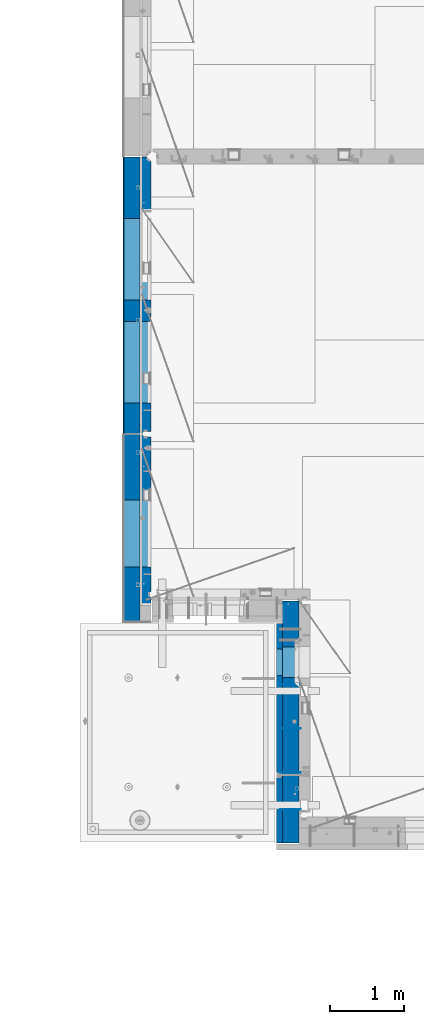
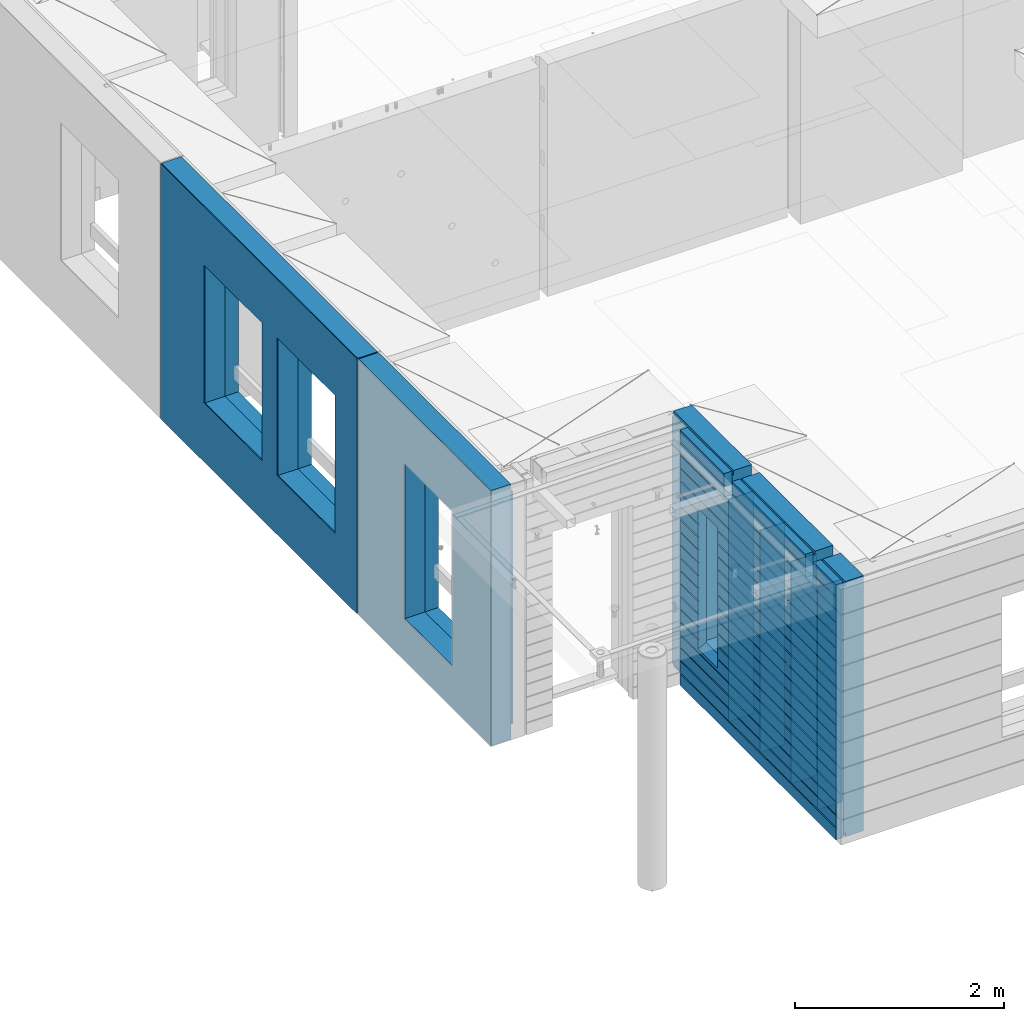
# One storey, part 227 of 349: 11 walls, 3 elements without a shape of their own.
"""IFC2X3 building model written with IfcOpenShell, lengths in millimetres."""

from ifc_helpers import new_model, si_unit, frame, origin_with_axes, place, context, subcontext, project, spatial, faceted_brep, material, type_object, element, aggregate, save


model = new_model("IFC2X3")

# Units and contexts
model_context = context("Model", 3, precision=1e-05, world=origin_with_axes())
body_context = subcontext(model_context, "Body", "Model", "MODEL_VIEW")
ifc_project = project(units=[si_unit("LENGTHUNIT", "METRE", prefix="MILLI"), si_unit("AREAUNIT", "SQUARE_METRE"), si_unit("VOLUMEUNIT", "CUBIC_METRE"), si_unit("MASSUNIT", "GRAM", prefix="KILO"), si_unit("TIMEUNIT", "SECOND"), si_unit("PLANEANGLEUNIT", "RADIAN"), si_unit("SOLIDANGLEUNIT", "STERADIAN"), si_unit("THERMODYNAMICTEMPERATUREUNIT", "DEGREE_CELSIUS"), si_unit("LUMINOUSINTENSITYUNIT", "LUMEN")], contexts=[model_context])

# Site, building, storey
site_placement = place(None, origin_with_axes())
site = spatial("IfcSite", under=ifc_project, at=site_placement, CompositionType="ELEMENT")
building_placement = place(site_placement, origin_with_axes())
building = spatial("IfcBuilding", under=site, at=building_placement, CompositionType="ELEMENT")
storey_placement = place(building_placement, origin_with_axes())
storey = spatial("IfcBuildingStorey", under=building, at=storey_placement, Name="4", CompositionType="ELEMENT", Elevation=0.0)

# Assembly, walls
assembly_1_placement = place(storey_placement, origin_with_axes())
assembly_1 = element("IfcElementAssembly", 1, at=assembly_1_placement, inside=storey, AssemblyPlace="NOTDEFINED", PredefinedType="REINFORCEMENT_UNIT")
ifc_material_1 = material(Name="Undefined")
wall_type_1 = type_object("IfcWallType", PredefinedType="NOTDEFINED")
wall_1_placement = place(assembly_1_placement, frame((10040.0, 8600.0, 92115.0), z_axis=(0.0, 0.0, 1.0), x_axis=(-1.0, 3.00000001838171e-08, 0.0)))
wall_1 = element("IfcWall", 2, at=wall_1_placement, type_object=wall_type_1, material=ifc_material_1, Name="(PD)", context=body_context, shape_type="Brep", body=[
    faceted_brep([(0.0, 5.0, -1300.0), (0.0, 5.0, 1300.0), (280.0, 5.0, 1300.0), (280.0, 5.0, -1300.0), (0.0, -5.0, 1300.0), (280.0, -5.0, 1300.0), (0.0, -5.0, -1300.0), (280.0, -5.0, -1300.0)], [[[0, 1, 2, 3]], [[1, 4, 5, 2]], [[4, 6, 7, 5]], [[6, 0, 3, 7]], [[5, 7, 3, 2]], [[6, 4, 1, 0]]]),
])
wall_2_placement = place(assembly_1_placement, frame((10040.0, 9200.0, 92115.0), z_axis=(0.0, 0.0, 1.0), x_axis=(-1.0, 3.00000001838171e-08, 0.0)))
wall_2 = element("IfcWall", 3, at=wall_2_placement, type_object=wall_type_1, material=ifc_material_1, Name="(PD)", context=body_context, shape_type="Brep", body=[
    faceted_brep([(0.0, 5.0, -1300.0), (0.0, 5.0, 1300.0), (280.0, 5.0, 1300.0), (280.0, 5.0, -1300.0), (0.0, -5.0, 1300.0), (280.0, -5.0, 1300.0), (0.0, -5.0, -1300.0), (280.0, -5.0, -1300.0)], [[[0, 1, 2, 3]], [[1, 4, 5, 2]], [[4, 6, 7, 5]], [[6, 0, 3, 7]], [[5, 7, 3, 2]], [[6, 4, 1, 0]]]),
])
wall_3_placement = place(assembly_1_placement, frame((10040.0, 8100.0, 92115.0), z_axis=(0.0, 0.0, 1.0), x_axis=(-1.0, 3.00000001838171e-08, 0.0)))
wall_3 = element("IfcWall", 4, at=wall_3_placement, type_object=wall_type_1, material=ifc_material_1, Name="(PD)", context=body_context, shape_type="Brep", body=[
    faceted_brep([(0.0, 5.0, -1300.0), (0.0, 5.0, 1300.0), (280.0, 5.0, 1300.0), (280.0, 5.0, -1300.0), (0.0, -5.0, 1300.0), (280.0, -5.0, 1300.0), (0.0, -5.0, -1300.0), (280.0, -5.0, -1300.0)], [[[0, 1, 2, 3]], [[1, 4, 5, 2]], [[4, 6, 7, 5]], [[6, 0, 3, 7]], [[5, 7, 3, 2]], [[6, 4, 1, 0]]]),
])
wall_4_placement = place(assembly_1_placement, frame((10040.0, 9800.0, 92115.0), z_axis=(0.0, 0.0, 1.0), x_axis=(-1.0, 3.00000001838171e-08, 0.0)))
wall_4 = element("IfcWall", 5, at=wall_4_placement, type_object=wall_type_1, material=ifc_material_1, Name="(PD)", context=body_context, shape_type="Brep", body=[
    faceted_brep([(0.0, 5.0, -1300.0), (0.0, 5.0, 1300.0), (280.0, 5.0, 1300.0), (280.0, 5.0, -1300.0), (0.0, -5.0, 1300.0), (280.0, -5.0, 1300.0), (0.0, -5.0, -1300.0), (280.0, -5.0, -1300.0)], [[[0, 1, 2, 3]], [[1, 4, 5, 2]], [[4, 6, 7, 5]], [[6, 0, 3, 7]], [[5, 7, 3, 2]], [[6, 4, 1, 0]]]),
])
ifc_material_2 = material(Name="COS5gt")
wall_type_2 = type_object("IfcWallType", PredefinedType="NOTDEFINED")
wall_5_placement = place(assembly_1_placement, frame((9900.0, 8000.0, 92247.5), z_axis=(0.0, 0.0, 1.0), x_axis=(0.0, 1.0, 0.0)))
wall_5 = element("IfcWall", 6, at=wall_5_placement, type_object=wall_type_2, material=ifc_material_2, context=body_context, shape_type="Brep", body=[
    faceted_brep([(2935.0, 90.0, 1492.5), (2935.0, 90.0, 1442.5), (1785.0, 90.0, 1442.5), (1785.0, 90.0, 1492.5), (2935.0, 110.0, 1442.5), (1785.0, 110.0, 1442.5), (1635.0, 90.0, 1442.5), (1635.0, 110.0, 1442.5), (229.999999999998, 110.0, 1442.5), (229.999999999998, 90.0, 1442.5), (1635.0, 90.0, 1492.5), (229.999999999998, 90.0, 1492.5), (1635.0, -110.0, 1492.5), (1635.0, -110.0, 1222.5), (1635.0, 110.0, 1222.5), (1785.0, -110.0, 1222.5), (1785.0, 110.0, 1222.5), (1785.0, -110.0, 1492.5), (2935.0, -110.0, 1492.5), (2935.0, -110.0, -1492.5), (-355.0, -110.0, -1492.5), (-355.0, 90.0, -1492.5), (2935.0, 90.0, -1492.5), (2935.0, 90.0, -1442.5), (2935.0, 110.0, -1442.5), (-355.0, 90.0, -1442.5), (-355.0, 110.0, -1442.5), (-355.0, -110.0, 1492.5), (-355.0, 90.0, 1492.5), (-355.0, 90.0, 1442.5), (-355.0, 110.0, 1442.5), (79.9999999999982, 90.0, 1442.5), (79.9999999999982, 110.0, 1442.5), (79.9999999999982, 110.0, 1222.5), (229.999999999998, 110.0, 1222.5), (1895.00042424099, 109.999999996904, -802.5), (1895.00042424099, 109.999999996904, -807.5), (1925.00042424099, 109.999999996904, -807.5), (2275.00042424099, 109.999999996904, -807.5), (2305.00042424099, 109.999999996904, -807.5), (2305.00042424099, 109.999999996904, -802.5), (2305.00042424099, 109.999999996904, 807.5), (1895.00042424099, 109.999999996904, 807.5), (1889.05447829513, -110.0, 813.445945945859), (2310.94637018685, -110.0, 813.445945945859), (1889.05447829513, -110.0, -813.445945945859), (2310.94637018685, -110.0, -813.445945945859), (79.9999999999982, -110.0, 1222.5), (79.9999999999982, -110.0, 1492.5), (229.999999999998, -110.0, 1492.5), (229.999999999998, -110.0, 1222.5), (79.9999999999982, 90.0, 1492.5)], [[[0, 1, 2, 3]], [[1, 4, 5, 2]], [[6, 7, 8, 9]], [[10, 6, 9, 11]], [[12, 13, 14, 7, 6, 10]], [[15, 16, 14, 13]], [[17, 3, 2, 5, 16, 15]], [[18, 0, 3, 17]], [[19, 20, 21, 22]], [[4, 1, 0, 18, 19, 22, 23, 24]], [[23, 25, 26, 24]], [[22, 21, 25, 23]], [[20, 27, 28, 29, 30, 26, 25, 21]], [[30, 29, 31, 32]], [[7, 14, 16, 5, 4, 24, 26, 30, 32, 33, 34, 8], [35, 36, 37, 38, 39, 40, 41, 42]], [[43, 42, 41, 44]], [[45, 36, 35, 42, 43]], [[46, 39, 38, 37, 36, 45]], [[44, 41, 40, 39, 46]], [[47, 48, 27, 20, 19, 18, 17, 15, 13, 12, 49, 50], [45, 43, 44, 46]], [[28, 27, 48, 51]], [[29, 28, 51, 31]], [[48, 47, 33, 32, 31, 51]], [[50, 34, 33, 47]], [[49, 11, 9, 8, 34, 50]], [[12, 10, 11, 49]]]),
])

# Assembly, wall
assembly_2_placement = place(storey_placement, origin_with_axes())
assembly_2 = element("IfcElementAssembly", 7, at=assembly_2_placement, inside=storey, AssemblyPlace="NOTDEFINED", PredefinedType="REINFORCEMENT_UNIT")
ifc_material_3 = material()
wall_6_placement = place(assembly_2_placement, frame((7739.99972588711, 13210.0004309454, 92247.5), z_axis=(0.0, 0.0, 1.0), x_axis=(0.0, 1.0, 0.0)))
wall_6 = element("IfcWall", 8, at=wall_6_placement, type_object=wall_type_2, material=ifc_material_3, context=body_context, shape_type="Brep", body=[
    faceted_brep([(0.0, 110.0, 1492.5), (0.0, -110.0, 1492.5), (3759.99957708461, -110.0, 1492.5), (3759.99956102462, 110.0, 1492.5), (0.0, -110.0, -1492.5), (0.0, 110.0, -1492.5), (3759.99956102462, 110.0, -1492.5), (3759.99957708461, -110.0, -1492.5), (414.999554466332, -110.0, -802.5), (414.999554466332, -110.0, 807.5), (1524.99955446633, -110.000000000001, 807.5), (1524.99955446633, -110.000000000001, -802.5), (1814.99999876569, -110.0, -802.5), (1814.99999876569, -110.0, 807.5), (2924.99999876569, -110.0, 807.5), (2924.99999876569, -110.0, -802.5), (1814.99999876569, 110.0, -802.5), (1814.99999876569, 110.0, 807.5), (2924.99999876569, 110.0, -802.5), (2924.99999876569, 110.0, 807.5), (414.999554466332, 110.0, -802.5), (1524.99955446633, 109.999999999999, -802.5), (1524.99955446633, 109.999999999999, 807.5), (414.999554466332, 110.0, 807.5)], [[[0, 1, 2, 3]], [[4, 1, 0, 5]], [[4, 5, 6, 7]], [[2, 7, 6, 3]], [[1, 4, 7, 2], [8, 9, 10, 11], [12, 13, 14, 15]], [[12, 16, 17, 13]], [[15, 18, 16, 12]], [[14, 19, 18, 15]], [[13, 17, 19, 14]], [[5, 0, 3, 6], [20, 21, 22, 23], [16, 18, 19, 17]], [[10, 22, 21, 11]], [[9, 23, 22, 10]], [[8, 20, 23, 9]], [[11, 21, 20, 8]]]),
])

assembly_3_placement = place(storey_placement, origin_with_axes())
assembly_3 = element("IfcElementAssembly", 9, at=assembly_3_placement, inside=storey, AssemblyPlace="NOTDEFINED", PredefinedType="REINFORCEMENT_UNIT")
wall_7_placement = place(assembly_3_placement, frame((7740.00002947772, 10874.9996836349, 92247.5), z_axis=(0.0, 0.0, 1.0), x_axis=(0.0, 1.0, 0.0)))
wall_7 = element("IfcWall", 10, at=wall_7_placement, type_object=wall_type_2, material=ifc_material_3, context=body_context, shape_type="Brep", body=[
    faceted_brep([(-219.99966922487, -110.0, 1492.5), (-219.99966922487, -110.0, -1492.5), (2320.00069431996, -110.000000000001, -1492.5), (2320.00069431996, -110.000000000001, 1492.5), (520.000578694053, -110.000000000001, -1002.5), (520.000578694053, -110.000000000001, 807.5), (1430.00057869405, -110.000000000001, 807.5), (1430.00057869405, -110.000000000001, -1002.5), (-219.99966922487, 110.0, 1492.5), (2320.00069431997, 110.0, 1492.5), (-219.99966922487, 110.0, -1492.5), (2320.00069431997, 110.0, -1492.5), (520.000578694055, 110.0, -1002.5), (1430.00057869406, 110.0, -1002.5), (1430.00057869406, 110.0, 807.5), (520.000578694055, 110.0, 807.5)], [[[0, 1, 2, 3], [4, 5, 6, 7]], [[8, 0, 3, 9]], [[1, 0, 8, 10]], [[1, 10, 11, 2]], [[3, 2, 11, 9]], [[10, 8, 9, 11], [12, 13, 14, 15]], [[6, 14, 13, 7]], [[5, 15, 14, 6]], [[4, 12, 15, 5]], [[7, 13, 12, 4]]]),
])

# Wall
ifc_material_4 = material(Name="CONCRETE/C30/37")
wall_type_3 = type_object("IfcWallType", PredefinedType="NOTDEFINED")
wall_8_placement = place(assembly_1_placement, frame((9747.5, 8000.0, 92247.5), z_axis=(0.0, 0.0, 1.0), x_axis=(0.0, 1.0, 0.0)))
wall_8 = element("IfcWall", 11, at=wall_8_placement, type_object=wall_type_3, material=ifc_material_4, context=body_context, shape_type="Brep", body=[
    faceted_brep([(-355.0, 32.4999992499324, 1344.99999999921), (-355.0, 32.4999991119385, 1355.00000040044), (79.9999999999982, 32.4999991119385, 1355.00000040044), (79.9999999999982, 32.4999992499324, 1344.99999999921), (-355.0, 42.5, 1342.99999994476), (79.9999999999982, 42.5, 1342.99999994476), (2630.0, 32.4999991119385, 1355.00000040044), (2630.0, 32.4999992499324, 1344.99999999921), (1785.0, 32.4999992499324, 1344.99999999921), (1785.0, 32.4999991119385, 1355.00000040044), (2630.0, 42.5, 1356.99999988925), (1785.0, 42.5, 1356.99999988925), (2630.0, 42.5, 1492.5), (1785.0, 42.5, 1492.5), (2630.0, -42.5, 1492.5), (1785.0, -42.5, 1492.5), (-355.0, -42.5, -1492.5), (-355.0, 42.5, -1492.5), (2630.0, 42.5, -1492.5), (2630.0, -42.5, -1492.5), (-355.0, 42.5, -1357.00000005524), (2630.0, 42.5, -1357.00000005524), (-355.0, 32.4999992506928, -1355.0000000008), (2630.0, 32.4999992506928, -1355.0000000008), (-355.0, 32.4999991126915, -1344.99999959957), (2630.0, 32.4999991126915, -1344.99999959957), (-355.0, 42.5, -1343.00000011075), (2630.0, 42.5, -1343.00000011075), (-355.0, 42.5, -1207.00000005524), (2630.0, 42.5, -1207.00000005524), (-355.0, 32.4999992506928, -1205.0000000008), (2630.0, 32.4999992506928, -1205.0000000008), (-355.0, 32.4999991126915, -1194.99999959957), (2630.0, 32.4999991126915, -1194.99999959957), (-355.0, 42.5, -1193.00000011075), (2630.0, 42.5, -1193.00000011075), (-355.0, 42.5, -1057.00000005525), (2630.0, 42.5, -1057.00000005525), (-355.0, 32.4999992512294, -1055.00000000081), (2630.0, 32.4999992512294, -1055.00000000081), (-355.0, 32.4999991132281, -1044.99999959959), (2630.0, 32.4999991132281, -1044.99999959959), (-355.0, 42.5, -1043.00000011077), (2630.0, 42.5, -1043.00000011077), (-355.0, 42.5, -907.000000055225), (2630.0, 42.5, -907.000000055225), (-355.000000000001, 32.4999992517678, -905.000000000786), (2630.0, 32.4999992517678, -905.000000000786), (-355.000000000001, 32.4999991137665, -894.99999959956), (2630.0, 32.4999991137665, -894.99999959956), (-355.0, 42.5, -893.00000011074), (2630.0, 42.5, -893.00000011074), (2630.0, 42.5, -307.000000055239), (2630.0, 32.4999992538942, -305.0000000008), (2630.0, 32.4999991158911, -294.999999599575), (2630.0, 42.5, -293.000000110755), (2630.0, 42.5, -157.000000055254), (2630.0, 32.4999992544235, -155.000000000815), (2630.0, 32.4999991164223, -144.99999959959), (2630.0, 42.5, -143.000000110769), (2630.0, 42.5, -7.00000005523907), (2630.0, 32.4999992500489, -5.0000000007858), (2630.0, 32.4999991120549, 5.0000004004396), (2630.0, 42.5, 6.99999988924537), (2630.0, 42.5, 142.999999944761), (2630.0, 32.4999992500361, 144.999999999214), (2630.0, 32.4999991120421, 155.00000040044), (2630.0, 42.5, 156.999999889245), (2630.0, 42.5, 292.999999944761), (2630.0, 32.4999992500234, 294.999999999214), (2630.0, 32.4999991120294, 305.00000040044), (2630.0, 42.5, 306.999999889245), (2630.0, 42.5, 442.999999944761), (2630.0, 32.4999992500107, 444.999999999214), (2630.0, 32.4999991120167, 455.00000040044), (2630.0, 42.5, 456.999999889245), (2630.0, 42.5, 592.999999944761), (2630.0, 32.4999992499979, 594.999999999214), (2630.0, 32.4999991120039, 605.00000040044), (2630.0, 42.5, 606.999999889245), (2630.0, 42.5, 742.999999944761), (2630.0, 32.4999992499852, 744.999999999214), (2630.0, 32.4999991119912, 755.00000040044), (2630.0, 42.5, 756.999999889245), (2630.0, 42.5, 892.999999944761), (2630.0, 32.4999992499725, 894.999999999214), (2630.0, 32.4999991119785, 905.00000040044), (2630.0, 42.5, 906.999999889245), (2630.0, 42.5, 1042.99999994476), (2630.0, 32.4999992499597, 1044.99999999921), (2630.0, 32.4999991119657, 1055.00000040044), (2630.0, 42.5, 1056.99999988925), (2630.0, 42.5, 1192.99999994476), (2630.0, 32.499999249947, 1194.99999999921), (2630.0, 32.499999111953, 1205.00000040044), (2630.0, 42.5, 1206.99999988925), (2630.0, 42.5, 1342.99999994476), (2630.0, 42.5, -757.000000055225), (2630.0, 32.4999992522953, -755.000000000786), (2630.0, 32.499999114294, -744.99999959956), (2630.0, 42.5, -743.00000011074), (2630.0, 42.5, -607.000000055225), (2630.0, 32.4999992522953, -605.000000000786), (2630.0, 32.499999114294, -594.99999959956), (2630.0, 42.5, -593.00000011074), (2630.0, 42.5, -457.000000055225), (2630.0, 32.4999992522953, -455.000000000786), (2630.0, 32.499999114294, -444.99999959956), (2630.0, 42.5, -443.00000011074), (1785.0, 42.5, 1342.99999994476), (1785.0, 42.5, 1222.5), (1785.0, -42.5, 1222.5), (1635.0, 42.5, 1222.5), (1635.0, -42.5, 1222.5), (1635.0, -42.5, 1492.5), (1635.0, 42.5, 1492.5), (229.999999999998, 42.5, 1492.5), (229.999999999998, -42.5, 1492.5), (1635.0, 32.4999991119385, 1355.00000040044), (1635.0, 32.4999992499324, 1344.99999999921), (229.999999999998, 32.4999992499324, 1344.99999999921), (229.999999999998, 32.4999991119385, 1355.00000040044), (1635.0, 42.5, 1356.99999988925), (229.999999999998, 42.5, 1356.99999988925), (1635.0, 42.5, 1342.99999994476), (229.999999999998, 42.5, 1342.99999994476), (229.999999999998, -42.5, 1222.5), (229.999999999998, 42.5, 1222.5), (79.9999999999982, 42.5, 1222.5), (79.9999999999982, -42.5, 1222.5), (-355.0, 42.5, 1206.99999988925), (-355.0, 32.499999111953, 1205.00000040044), (-355.0, 32.499999249947, 1194.99999999921), (-355.0, 42.5, 1192.99999994476), (-355.0, 42.5, 1056.99999988925), (-355.0, 32.4999991119657, 1055.00000040044), (-355.0, 32.4999992499597, 1044.99999999921), (-355.0, 42.5, 1042.99999994476), (-355.0, 42.5, 906.999999889245), (-354.999999999999, 32.4999991119785, 905.00000040044), (-354.999999999999, 32.4999992499725, 894.999999999214), (-355.0, 42.5, 892.999999944761), (-355.0, 42.5, -457.000000055225), (-355.0, 42.5, -593.00000011074), (-354.999999999998, 32.499999114294, -594.99999959956), (-354.999999999998, 32.4999992522953, -605.000000000786), (-355.0, 42.5, -607.000000055225), (-355.0, 42.5, -743.00000011074), (-355.0, 32.499999114294, -744.99999959956), (-355.0, 32.4999992522953, -755.000000000786), (-355.0, 42.5, -757.000000055225), (-355.0, -42.5, 1492.5), (-355.0, 42.5, 1492.5), (-355.0, 42.5, 1356.99999988925), (-355.0, 42.5, 756.999999889245), (-354.999999999999, 32.4999991119912, 755.00000040044), (-354.999999999999, 32.4999992499852, 744.999999999214), (-355.0, 42.5, 742.999999944761), (-355.0, 42.5, 606.999999889245), (-355.0, 32.4999991120039, 605.00000040044), (-355.0, 32.4999992499979, 594.999999999214), (-355.0, 42.5, 592.999999944761), (-355.0, 42.5, 456.999999889245), (-355.0, 32.4999991120167, 455.00000040044), (-355.0, 32.4999992500107, 444.999999999214), (-355.0, 42.5, 442.999999944761), (-355.0, 42.5, 306.999999889245), (-355.0, 32.4999991120294, 305.00000040044), (-355.0, 32.4999992500234, 294.999999999214), (-355.0, 42.5, 292.999999944761), (-355.0, 42.5, 156.999999889245), (-355.0, 32.4999991120421, 155.00000040044), (-355.0, 32.4999992500361, 144.999999999214), (-355.0, 42.5, 142.999999944761), (-355.0, 42.5, 6.99999988924537), (-355.0, 32.4999991120549, 5.0000004004396), (-355.0, 32.4999992500489, -5.0000000007858), (-355.0, 42.5, -7.00000005523907), (-355.0, 42.5, -143.000000110769), (-354.999999999999, 32.4999991164223, -144.99999959959), (-354.999999999999, 32.4999992544235, -155.000000000815), (-355.0, 42.5, -157.000000055254), (-355.0, 42.5, -293.000000110755), (-355.0, 32.4999991158911, -294.999999599575), (-355.0, 32.4999992538942, -305.0000000008), (-355.0, 42.5, -307.000000055239), (-355.0, 42.5, -443.00000011074), (-355.000000000001, 32.499999114294, -444.99999959956), (-355.000000000001, 32.4999992522953, -455.000000000786), (1915.00042424099, 42.5, 756.999999889245), (1916.1768949337, 32.4999991119912, 755.00000040044), (1916.17689491746, 32.4999992499852, 744.999999999214), (1915.00042424099, 42.5, 742.999999944761), (1915.00042424099, 42.5, 606.999999889245), (1916.17689493369, 32.4999991120039, 605.00000040044), (1916.17689491746, 32.4999992499979, 594.999999999214), (1915.00042424099, 42.5, 592.999999944761), (1915.00042424099, 42.5, 456.999999889245), (1916.17689493369, 32.4999991120167, 455.00000040044), (1916.17689491746, 32.4999992500107, 444.999999999214), (1915.00042424099, 42.5, 442.999999944761), (1915.00042424099, 42.5, 306.999999889245), (1916.17689493369, 32.4999991120294, 305.00000040044), (1916.17689491746, 32.4999992500234, 294.999999999214), (1915.00042424099, 42.5, 292.999999944761), (1915.00042424099, 42.5, 156.999999889245), (1916.17689493369, 32.4999991120421, 155.00000040044), (1916.17689491745, 32.4999992500361, 144.999999999214), (1915.00042424099, 42.5, 142.999999944761), (1915.00042424099, 42.5, 6.99999988924537), (1916.17689493369, 32.4999991120549, 5.0000004004396), (1916.17689491745, 32.4999992500489, -5.0000000007858), (1915.00042424099, 42.5, -7.00000005523907), (1915.00042424099, 42.5, -143.000000110769), (1916.17689493317, 32.4999991164223, -144.99999959959), (1916.17689491694, 32.4999992544235, -155.000000000815), (1915.00042424099, 42.5, -157.000000055254), (1915.00042424099, 42.5, -293.000000110755), (1916.17689493324, 32.4999991158911, -294.999999599575), (1916.176894917, 32.4999992538942, -305.0000000008), (1915.00042424099, 42.5, -307.000000055239), (1915.00042424099, 42.5, -443.00000011074), (1916.17689493342, 32.499999114294, -444.99999959956), (1916.17689491719, 32.4999992522953, -455.000000000786), (1915.00042424099, 42.5, -457.000000055225), (1915.00042424099, 42.5, -593.00000011074), (1916.17689493343, 32.499999114294, -594.99999959956), (1916.17689491719, 32.4999992522953, -605.000000000786), (1915.00042424099, 42.5, -607.000000055225), (1915.00042424099, 42.5, -743.00000011074), (1916.17689493343, 32.499999114294, -744.99999959956), (1916.17689491719, 32.4999992522953, -755.000000000786), (1915.00042424099, 42.5, -757.000000055225), (1915.00042424099, 42.5, -857.5), (2285.00042424099, 42.5, -857.5), (2285.00042424099, 42.5, -757.000000055225), (2283.82395356479, 32.4999992522953, -755.000000000786), (2283.82395354855, 32.499999114294, -744.99999959956), (2285.00042424099, 42.5, -743.00000011074), (2285.00042424099, 42.5, -607.000000055225), (2283.82395356479, 32.4999992522953, -605.000000000786), (2283.82395354855, 32.499999114294, -594.99999959956), (2285.00042424099, 42.5, -593.00000011074), (2285.00042424099, 42.5, -457.000000055225), (2283.82395356479, 32.4999992522953, -455.000000000786), (2283.82395354855, 32.499999114294, -444.99999959956), (2285.00042424099, 42.5, -443.00000011074), (2285.00042424099, 42.5, -307.000000055239), (2283.82395356498, 32.4999992538942, -305.0000000008), (2283.82395354874, 32.4999991158911, -294.999999599575), (2285.00042424099, 42.5, -293.000000110755), (2285.00042424099, 42.5, -157.000000055254), (2283.82395356504, 32.4999992544235, -155.000000000815), (2283.8239535488, 32.4999991164223, -144.99999959959), (2285.00042424099, 42.5, -143.000000110769), (2285.00042424099, 42.5, -7.00000005523907), (2283.82395356452, 32.4999992500489, -5.0000000007858), (2283.82395354829, 32.4999991120549, 5.0000004004396), (2285.00042424099, 42.5, 6.99999988924537), (2285.00042424099, 42.5, 142.999999944761), (2283.82395356452, 32.4999992500361, 144.999999999214), (2283.82395354829, 32.4999991120421, 155.00000040044), (2285.00042424099, 42.5, 156.999999889245), (2285.00042424099, 42.5, 292.999999944761), (2283.82395356452, 32.4999992500234, 294.999999999214), (2283.82395354829, 32.4999991120294, 305.00000040044), (2285.00042424099, 42.5, 306.999999889245), (2285.00042424099, 42.5, 442.999999944761), (2283.82395356452, 32.4999992500107, 444.999999999214), (2283.82395354828, 32.4999991120167, 455.00000040044), (2285.00042424099, 42.5, 456.999999889245), (2285.00042424099, 42.5, 592.999999944761), (2283.82395356452, 32.4999992499979, 594.999999999214), (2283.82395354828, 32.4999991120039, 605.00000040044), (2285.00042424099, 42.5, 606.999999889245), (2285.00042424099, 42.5, 742.999999944761), (2283.82395356452, 32.4999992499852, 744.999999999214), (2283.82395354828, 32.4999991119912, 755.00000040044), (2285.00042424099, 42.5, 756.999999889245), (1925.00042424099, 42.5, 782.5), (1915.00042424099, 42.5, 782.5), (2285.00042424099, 42.5, 782.5), (2275.00042424099, 42.5, 782.5), (1925.00042424099, -42.5, 787.5), (2275.00042424099, -42.5, 787.5), (1925.00042424099, -42.5, 782.5), (1925.00042424099, -42.5, -807.5), (2275.00042424099, -42.5, -807.5), (2275.00042424099, -42.5, 782.5), (79.9999999999982, -42.5, 1492.5), (79.9999999999982, 42.5, 1492.5), (79.9999999999982, 42.5, 1356.99999988925)], [[[0, 1, 2, 3]], [[4, 0, 3, 5]], [[6, 7, 8, 9]], [[10, 6, 9, 11]], [[12, 10, 11, 13]], [[14, 12, 13, 15]], [[16, 17, 18, 19]], [[18, 17, 20, 21]], [[21, 20, 22, 23]], [[23, 22, 24, 25]], [[25, 24, 26, 27]], [[28, 29, 27, 26]], [[29, 28, 30, 31]], [[31, 30, 32, 33]], [[33, 32, 34, 35]], [[35, 34, 36, 37]], [[37, 36, 38, 39]], [[39, 38, 40, 41]], [[41, 40, 42, 43]], [[43, 42, 44, 45]], [[45, 44, 46, 47]], [[47, 46, 48, 49]], [[49, 48, 50, 51]], [[52, 53, 54, 55, 56, 57, 58, 59, 60, 61, 62, 63, 64, 65, 66, 67, 68, 69, 70, 71, 72, 73, 74, 75, 76, 77, 78, 79, 80, 81, 82, 83, 84, 85, 86, 87, 88, 89, 90, 91, 92, 93, 94, 95, 96, 7, 6, 10, 12, 14, 19, 18, 21, 23, 25, 27, 29, 31, 33, 35, 37, 39, 41, 43, 45, 47, 49, 51, 97, 98, 99, 100, 101, 102, 103, 104, 105, 106, 107, 108]], [[7, 96, 109, 8]], [[15, 13, 11, 9, 8, 109, 110, 111]], [[111, 110, 112, 113]], [[114, 115, 116, 117]], [[118, 119, 120, 121]], [[122, 118, 121, 123]], [[115, 122, 123, 116]], [[114, 113, 112, 124, 119, 118, 122, 115]], [[119, 124, 125, 120]], [[126, 127, 128, 129]], [[117, 116, 123, 121, 120, 125, 127, 126]], [[124, 112, 110, 109, 96, 95, 130, 4, 5, 128, 127, 125]], [[94, 131, 130, 95]], [[93, 132, 131, 94]], [[92, 133, 132, 93]], [[91, 134, 133, 92]], [[90, 135, 134, 91]], [[89, 136, 135, 90]], [[88, 137, 136, 89]], [[87, 138, 137, 88]], [[86, 139, 138, 87]], [[85, 140, 139, 86]], [[84, 141, 140, 85]], [[142, 143, 144, 145, 146, 147, 148, 149, 150, 50, 48, 46, 44, 42, 40, 38, 36, 34, 32, 30, 28, 26, 24, 22, 20, 17, 16, 151, 152, 153, 1, 0, 4, 130, 131, 132, 133, 134, 135, 136, 137, 138, 139, 140, 141, 154, 155, 156, 157, 158, 159, 160, 161, 162, 163, 164, 165, 166, 167, 168, 169, 170, 171, 172, 173, 174, 175, 176, 177, 178, 179, 180, 181, 182, 183, 184, 185, 186, 187, 188]], [[155, 154, 189, 190]], [[156, 155, 190, 191]], [[157, 156, 191, 192]], [[158, 157, 192, 193]], [[159, 158, 193, 194]], [[160, 159, 194, 195]], [[161, 160, 195, 196]], [[162, 161, 196, 197]], [[163, 162, 197, 198]], [[164, 163, 198, 199]], [[165, 164, 199, 200]], [[166, 165, 200, 201]], [[167, 166, 201, 202]], [[168, 167, 202, 203]], [[169, 168, 203, 204]], [[170, 169, 204, 205]], [[171, 170, 205, 206]], [[172, 171, 206, 207]], [[173, 172, 207, 208]], [[174, 173, 208, 209]], [[175, 174, 209, 210]], [[176, 175, 210, 211]], [[177, 176, 211, 212]], [[178, 177, 212, 213]], [[179, 178, 213, 214]], [[180, 179, 214, 215]], [[181, 180, 215, 216]], [[182, 181, 216, 217]], [[183, 182, 217, 218]], [[184, 183, 218, 219]], [[185, 184, 219, 220]], [[186, 185, 220, 221]], [[187, 186, 221, 222]], [[188, 187, 222, 223]], [[142, 188, 223, 224]], [[143, 142, 224, 225]], [[144, 143, 225, 226]], [[145, 144, 226, 227]], [[146, 145, 227, 228]], [[147, 146, 228, 229]], [[148, 147, 229, 230]], [[149, 148, 230, 231]], [[150, 149, 231, 232]], [[97, 51, 50, 150, 232, 233, 234, 235]], [[98, 97, 235, 236]], [[99, 98, 236, 237]], [[100, 99, 237, 238]], [[101, 100, 238, 239]], [[102, 101, 239, 240]], [[103, 102, 240, 241]], [[104, 103, 241, 242]], [[105, 104, 242, 243]], [[106, 105, 243, 244]], [[107, 106, 244, 245]], [[108, 107, 245, 246]], [[52, 108, 246, 247]], [[53, 52, 247, 248]], [[54, 53, 248, 249]], [[55, 54, 249, 250]], [[56, 55, 250, 251]], [[57, 56, 251, 252]], [[58, 57, 252, 253]], [[59, 58, 253, 254]], [[60, 59, 254, 255]], [[61, 60, 255, 256]], [[62, 61, 256, 257]], [[63, 62, 257, 258]], [[64, 63, 258, 259]], [[65, 64, 259, 260]], [[66, 65, 260, 261]], [[67, 66, 261, 262]], [[68, 67, 262, 263]], [[69, 68, 263, 264]], [[70, 69, 264, 265]], [[71, 70, 265, 266]], [[72, 71, 266, 267]], [[73, 72, 267, 268]], [[74, 73, 268, 269]], [[75, 74, 269, 270]], [[76, 75, 270, 271]], [[77, 76, 271, 272]], [[78, 77, 272, 273]], [[79, 78, 273, 274]], [[80, 79, 274, 275]], [[81, 80, 275, 276]], [[82, 81, 276, 277]], [[83, 82, 277, 278]], [[279, 280, 189, 154, 141, 84, 83, 278, 281, 282]], [[283, 280, 279, 282, 281, 284]], [[285, 286, 233, 232, 231, 230, 229, 228, 227, 226, 225, 224, 223, 222, 221, 220, 219, 218, 217, 216, 215, 214, 213, 212, 211, 210, 209, 208, 207, 206, 205, 204, 203, 202, 201, 200, 199, 198, 197, 196, 195, 194, 193, 192, 191, 190, 189, 280, 283]], [[287, 234, 233, 286]], [[288, 284, 281, 278, 277, 276, 275, 274, 273, 272, 271, 270, 269, 268, 267, 266, 265, 264, 263, 262, 261, 260, 259, 258, 257, 256, 255, 254, 253, 252, 251, 250, 249, 248, 247, 246, 245, 244, 243, 242, 241, 240, 239, 238, 237, 236, 235, 234, 287]], [[129, 289, 151, 16, 19, 14, 15, 111, 113, 114, 117, 126], [287, 286, 285, 283, 284, 288]], [[152, 151, 289, 290]], [[153, 152, 290, 291]], [[289, 129, 128, 5, 3, 2, 291, 290]], [[1, 153, 291, 2]]]),
])

aggregate(assembly_1, [wall_1, wall_2, wall_3, wall_4, wall_5, wall_8])

ifc_material_5 = material(Name="CONCRETE/C25/30")
wall_type_4 = type_object("IfcWallType", PredefinedType="NOTDEFINED")
wall_9_placement = place(assembly_2_placement, frame((7924.9997258893, 13210.0004174404, 92112.5), z_axis=(0.0, 0.0, 1.0), x_axis=(0.0, 1.0, 0.0)))
wall_9 = element("IfcWall", 12, at=wall_9_placement, type_object=wall_type_4, material=ifc_material_5, context=body_context, shape_type="Brep", body=[
    faceted_brep([(1524.99955451006, -75.0000000617138, -667.5), (1524.99955451006, 75.0, -667.5), (414.999554510065, 75.0, -667.5), (414.999554510063, -75.000000114278, -667.5), (414.999554510065, 75.0, 942.5), (414.999554510063, -75.0000002207053, 942.5), (1524.99955451006, 75.0, 942.5), (1524.99955451006, -75.000000168141, 942.5), (0.0, 45.0, 1357.5), (0.0, 45.0, -1357.5), (29.9999989126591, 32.0000004547946, -1357.5), (29.9999989126591, 32.0000004547946, 1357.5), (0.0, 75.0, 1357.5), (0.0, 75.0, -1357.5), (3759.99957708464, 74.9999999999991, -1357.5), (3759.99957708464, 74.9999999999991, 1357.5), (3759.99958365464, -14.9999989005837, 1357.5), (3759.99958365464, -14.9999989005837, -1357.5), (30.0000016637459, -75.0, -1357.5), (3699.99959131522, -75.0000000000018, -1357.5), (30.0000016637459, -75.0, 1357.5), (3699.99959130954, -75.0000000056843, 1357.5), (1814.99999880942, -75.0000000486807, -667.5), (1814.99999880942, -75.0000001534236, 942.5), (2924.99999880942, -75.0000001008593, 942.5), (2924.99999880942, -74.9999999961165, -667.5), (1814.99999880942, 74.9999999999991, -667.5), (1814.99999880942, 74.9999999999991, 942.5), (2924.99999880942, 74.9999999999991, -667.5), (2924.99999880942, 74.9999999999991, 942.5)], [[[0, 1, 2, 3]], [[3, 2, 4, 5]], [[5, 4, 6, 7]], [[7, 6, 1, 0]], [[8, 9, 10, 11]], [[12, 13, 9, 8]], [[14, 15, 16, 17]], [[18, 10, 9, 13, 14, 17, 19]], [[11, 10, 18, 20]], [[15, 12, 8, 11, 20, 21, 16]], [[17, 16, 21, 19]], [[20, 18, 19, 21], [3, 5, 7, 0], [22, 23, 24, 25]], [[22, 26, 27, 23]], [[25, 28, 26, 22]], [[24, 29, 28, 25]], [[23, 27, 29, 24]], [[13, 12, 15, 14], [2, 1, 6, 4], [26, 28, 29, 27]]]),
])

wall_10_placement = place(assembly_3_placement, frame((7924.99999901751, 11107.4999902026, 92112.5), z_axis=(0.0, 0.0, 1.0), x_axis=(0.0, 1.0, 0.0)))
wall_10 = element("IfcWall", 13, at=wall_10_placement, type_object=wall_type_4, material=ifc_material_5, context=body_context, shape_type="Brep", body=[
    faceted_brep([(1197.50029630646, -74.9999998966041, -867.5), (1197.50029630646, 74.9999999999982, -867.5), (287.500296306462, 74.9999999999991, -867.5), (287.500296306462, -74.9999993964047, -867.5), (287.500296306462, 74.9999999999991, 942.5), (287.500296306462, -74.9999986286903, 942.5), (1197.50029630646, 74.9999999999982, 942.5), (1197.50029630646, -74.9999991288896, 942.5), (2087.5004119875, 44.9999999972642, 1357.5), (2087.5004119875, 74.9999999999991, 1357.5), (-232.500282332605, 74.9999999999991, 1357.5), (-232.500282332603, -75.0000000000009, 1357.5), (-122.50000002761, -75.0000000000009, 1357.5), (-109.499996997054, -54.9999860283524, 1357.5), (-55.4999970925001, -54.9999931295279, 1357.5), (-42.4999972430833, -74.9999976941244, 1357.5), (2057.50041198727, -75.0000000027349, 1357.5), (2057.50041198727, 24.9999999972651, 1357.5), (-232.500282332603, -75.0000000000009, -1357.5), (-232.500282332605, 74.9999999999991, -1357.5), (-122.50000002761, -75.0000000000009, -1357.5), (-109.499996997054, -54.9999860283524, -1357.5), (-55.4999970925001, -54.9999931295279, -1357.5), (-42.4999972430851, -75.0000000000009, -1357.5), (2057.50041198727, -75.0000000000009, -1357.5), (2057.50041198727, 24.9999999972651, -1357.5), (2087.5004119875, 74.9999999999991, -1357.5), (2087.5004119875, 44.9999999972642, -1357.5)], [[[0, 1, 2, 3]], [[3, 2, 4, 5]], [[5, 4, 6, 7]], [[7, 6, 1, 0]], [[8, 9, 10, 11, 12, 13, 14, 15, 16, 17]], [[18, 11, 10, 19]], [[11, 18, 20, 12]], [[12, 20, 21, 13]], [[13, 21, 22, 14]], [[15, 14, 22, 23]], [[15, 23, 24, 16], [3, 5, 7, 0]], [[16, 24, 25, 17]], [[23, 22, 21, 20, 18, 19, 26, 27, 25, 24]], [[17, 25, 27, 8]], [[26, 9, 8, 27]], [[19, 10, 9, 26], [2, 1, 6, 4]]]),
])

aggregate(assembly_3, [wall_7, wall_10])

wall_type_5 = type_object("IfcWallType", PredefinedType="NOTDEFINED")
wall_11_placement = place(assembly_2_placement, frame((7624.9997258871, 13210.0004393404, 92247.5), z_axis=(0.0, 0.0, 1.0), x_axis=(0.0, 1.0, 0.0)))
wall_11 = element("IfcWall", 14, at=wall_11_placement, type_object=wall_type_5, material=ifc_material_4, context=body_context, shape_type="Brep", body=[
    faceted_brep([(0.0, 5.0, 1492.5), (0.0, -5.0, 1492.5), (3759.99956102465, -5.00000000000091, 1492.5), (3759.99956029465, 4.99999999999909, 1492.5), (0.0, -5.0, -1492.5), (0.0, 5.0, -1492.5), (3759.99956029465, 4.99999999999909, -1492.5), (3759.99956102465, -5.00000000000091, -1492.5), (414.999554402322, -5.00000000000091, -802.5), (414.999554402322, -5.00000000000091, 807.5), (1524.99955440232, -5.00000000000182, 807.5), (1524.99955440232, -5.00000000000182, -802.5), (1814.99999870163, -5.00000000000091, -802.5), (1814.99999870163, -5.00000000000091, 807.5), (2924.99999870163, -5.00000000000091, 807.5), (2924.99999870163, -5.00000000000091, -802.5), (1814.99999870163, 4.99999999999909, -802.5), (1814.99999870163, 4.99999999999909, 807.5), (2924.99999870163, 4.99999999999909, -802.5), (2924.99999870163, 4.99999999999909, 807.5), (414.999554402326, 4.99999999999818, -802.5), (1524.99955440232, 4.99999999999818, -802.5), (1524.99955440232, 4.99999999999818, 807.5), (414.999554402326, 4.99999999999818, 807.5)], [[[0, 1, 2, 3]], [[4, 1, 0, 5]], [[4, 5, 6, 7]], [[2, 7, 6, 3]], [[1, 4, 7, 2], [8, 9, 10, 11], [12, 13, 14, 15]], [[12, 16, 17, 13]], [[15, 18, 16, 12]], [[14, 19, 18, 15]], [[13, 17, 19, 14]], [[5, 0, 3, 6], [20, 21, 22, 23], [16, 18, 19, 17]], [[10, 22, 21, 11]], [[9, 23, 22, 10]], [[8, 20, 23, 9]], [[11, 21, 20, 8]]]),
])

aggregate(assembly_2, [wall_11, wall_6, wall_9])

save(model, "model.ifc")
